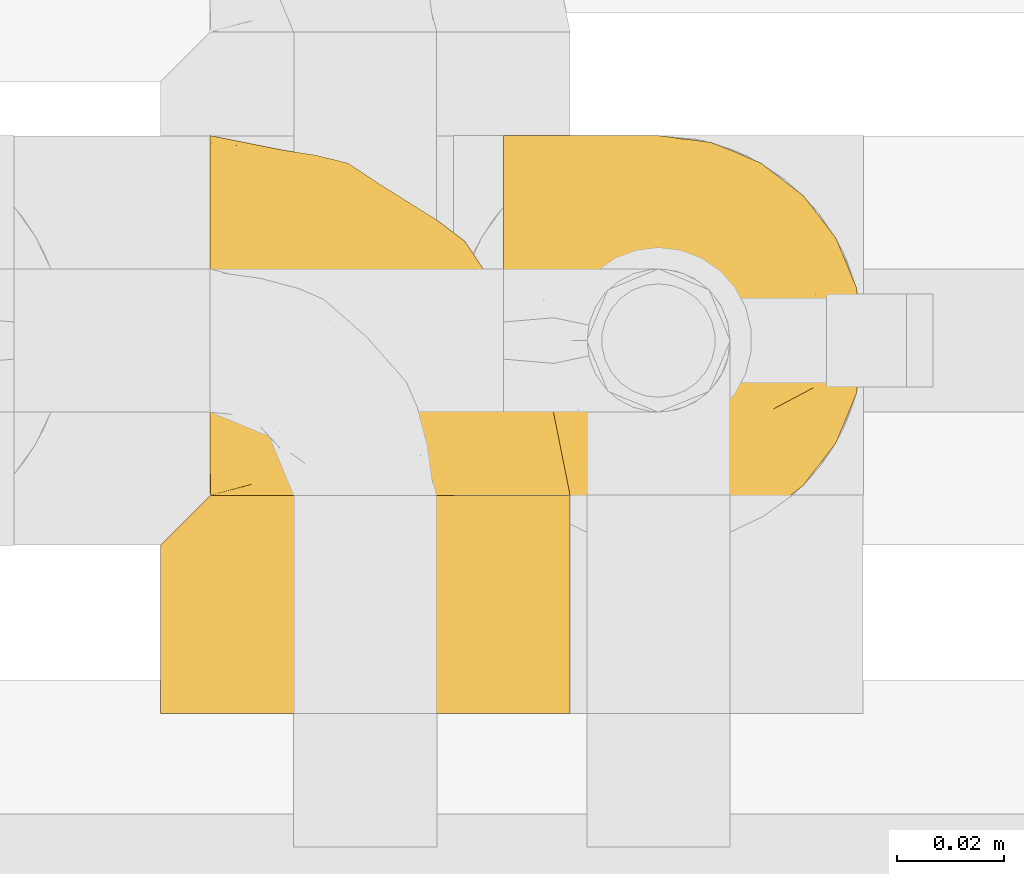
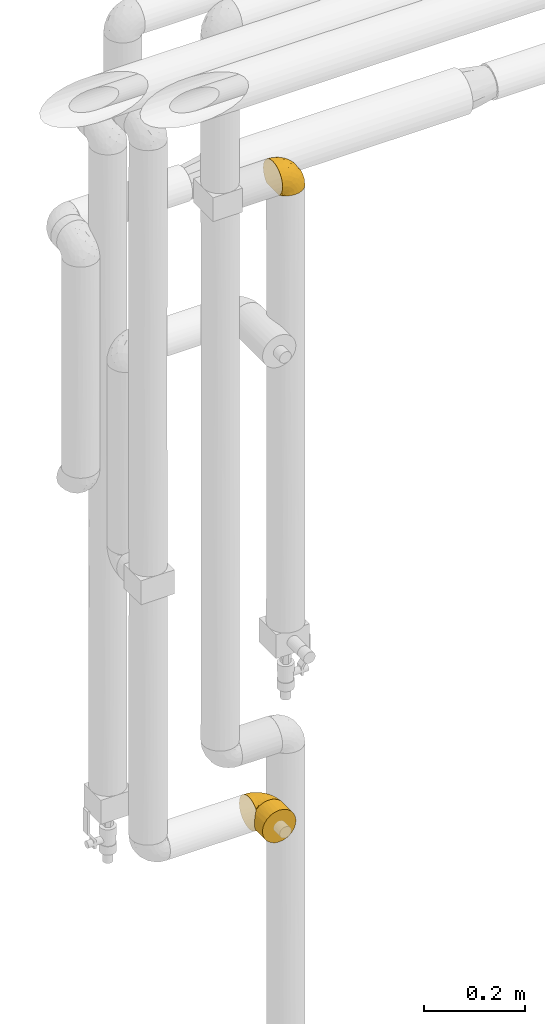
# One storey, part 331 of 827: 3 coverings.
"""IFC2X3 building model written with IfcOpenShell, lengths in millimetres."""

from ifc_helpers import new_model, entity, si_unit, converted_unit, derived_unit, direction, frame, origin, place, context, subcontext, project, spatial, faceted_brep, element, save


model = new_model("IFC2X3")

# Units and contexts
model_context = context("Model", 3, precision=0.01, world=origin(), true_north=direction((6.12303176911189e-17, 1.0)))
body_context = subcontext(model_context, "Body", "Model", "MODEL_VIEW")
ifc_project = project(units=[si_unit("LENGTHUNIT", "METRE", prefix="MILLI"), si_unit("AREAUNIT", "SQUARE_METRE"), si_unit("VOLUMEUNIT", "CUBIC_METRE"), converted_unit("PLANEANGLEUNIT", "DEGREE", entity("IfcRatioMeasure", 0.0174532925199433), si_unit("PLANEANGLEUNIT", "RADIAN"), dimensions=[0, 0, 0, 0, 0, 0, 0]), si_unit("MASSUNIT", "GRAM", prefix="KILO"), derived_unit("MASSDENSITYUNIT", [(si_unit("MASSUNIT", "GRAM", prefix="KILO"), 1), (si_unit("LENGTHUNIT", "METRE"), -3)]), derived_unit("MOMENTOFINERTIAUNIT", [(si_unit("LENGTHUNIT", "METRE"), 4)]), si_unit("TIMEUNIT", "SECOND"), si_unit("FREQUENCYUNIT", "HERTZ"), si_unit("THERMODYNAMICTEMPERATUREUNIT", "DEGREE_CELSIUS"), derived_unit("THERMALTRANSMITTANCEUNIT", [(si_unit("MASSUNIT", "GRAM", prefix="KILO"), 1), (si_unit("THERMODYNAMICTEMPERATUREUNIT", "KELVIN"), -1), (si_unit("TIMEUNIT", "SECOND"), -3)]), derived_unit("VOLUMETRICFLOWRATEUNIT", [(si_unit("LENGTHUNIT", "METRE"), 3), (si_unit("TIMEUNIT", "SECOND"), -1)]), derived_unit("MASSFLOWRATEUNIT", [(si_unit("MASSUNIT", "GRAM", prefix="KILO"), 1), (si_unit("TIMEUNIT", "SECOND"), -1)]), derived_unit("ROTATIONALFREQUENCYUNIT", [(si_unit("TIMEUNIT", "SECOND"), -1)]), si_unit("ELECTRICCURRENTUNIT", "AMPERE"), si_unit("ELECTRICVOLTAGEUNIT", "VOLT"), si_unit("POWERUNIT", "WATT"), si_unit("FORCEUNIT", "NEWTON", prefix="KILO"), si_unit("ILLUMINANCEUNIT", "LUX"), si_unit("LUMINOUSFLUXUNIT", "LUMEN"), si_unit("LUMINOUSINTENSITYUNIT", "CANDELA"), derived_unit("USERDEFINED", [(si_unit("MASSUNIT", "GRAM", prefix="KILO"), -1), (si_unit("LENGTHUNIT", "METRE"), -2), (si_unit("TIMEUNIT", "SECOND"), 3), (si_unit("LUMINOUSFLUXUNIT", "LUMEN"), 1)]), derived_unit("LINEARVELOCITYUNIT", [(si_unit("LENGTHUNIT", "METRE"), 1), (si_unit("TIMEUNIT", "SECOND"), -1)]), si_unit("PRESSUREUNIT", "PASCAL"), derived_unit("USERDEFINED", [(si_unit("LENGTHUNIT", "METRE"), -2), (si_unit("MASSUNIT", "GRAM", prefix="KILO"), 1), (si_unit("TIMEUNIT", "SECOND"), -2)]), derived_unit("LINEARFORCEUNIT", [(si_unit("MASSUNIT", "GRAM", prefix="KILO"), 1), (si_unit("LENGTHUNIT", "METRE"), 1), (si_unit("TIMEUNIT", "SECOND"), -2), (si_unit("LENGTHUNIT", "METRE"), -1)]), derived_unit("PLANARFORCEUNIT", [(si_unit("MASSUNIT", "GRAM", prefix="KILO"), 1), (si_unit("LENGTHUNIT", "METRE"), 1), (si_unit("TIMEUNIT", "SECOND"), -2), (si_unit("LENGTHUNIT", "METRE"), -2)])], contexts=[model_context])

# Site, building, storey
site_placement = place(None, origin())
site = spatial("IfcSite", under=ifc_project, at=site_placement, CompositionType="ELEMENT")
building_placement = place(site_placement, origin())
building = spatial("IfcBuilding", under=site, at=building_placement, CompositionType="ELEMENT")
storey_placement = place(building_placement, frame((0.0, 0.0, 28200.0)))
storey = spatial("IfcBuildingStorey", under=building, at=storey_placement, Name="08", CompositionType="ELEMENT", Elevation=28200.0)

# Coverings
covering_1_placement = place(storey_placement, frame((34809.73, 18294.87, 2549.3)))
element("IfcCovering", 1, at=covering_1_placement, inside=storey, Name=":ADSK_", ObjectType=":ADSK_", PredefinedType="INSULATION", context=body_context, shape_type="Brep", body=[
    faceted_brep([(1.6, 5.41, 47.38), (1.6, 9.99, 54.67), (1.6, 16.08, 60.76), (1.6, 23.37, 65.34), (1.6, 31.49, 68.18), (1.6, 40.05, 69.15), (1.6, 48.61, 68.18), (1.6, 56.73, 65.33), (1.6, 64.02, 60.75), (1.6, 70.11, 54.66), (1.6, 74.69, 47.37), (1.6, 77.53, 39.25), (1.6, 78.5, 30.7), (1.6, 77.63, 22.59), (1.6, 75.08, 14.86), (1.6, 70.97, 7.84), (1.6, 65.47, 1.85), (1.6, 63.27, 1.85), (1.6, 61.53, 1.85), (1.6, 59.57, 1.85), (1.6, 57.6, 1.85), (1.6, 55.63, 1.85), (1.6, 53.67, 1.85), (1.6, 51.7, 1.85), (1.6, 49.73, 1.85), (1.6, 47.54, 1.85), (1.6, 45.34, 1.85), (1.6, 43.15, 1.85), (1.6, 40.96, 1.85), (1.6, 38.76, 1.85), (1.6, 36.57, 1.85), (1.6, 34.37, 1.85), (1.6, 32.18, 1.85), (1.6, 29.98, 1.85), (1.6, 27.79, 1.85), (1.6, 25.6, 1.85), (1.6, 23.4, 1.85), (1.6, 21.21, 1.85), (1.6, 19.01, 1.85), (1.6, 16.82, 1.85), (1.6, 14.62, 1.85), (1.6, 9.12, 7.85), (1.6, 5.0, 14.88), (1.6, 2.46, 22.61), (1.6, 1.6, 30.7), (1.6, 2.56, 39.26), (1.85, 65.47, 1.6), (7.85, 70.97, 1.6), (14.87, 75.09, 1.6), (22.6, 77.63, 1.6), (30.7, 78.5, 1.6), (40.65, 77.19, 1.6), (49.92, 73.34, 1.6), (57.88, 67.23, 1.6), (63.99, 59.27, 1.6), (67.84, 50.0, 1.6), (69.15, 40.05, 1.6), (67.84, 30.09, 1.6), (63.99, 20.82, 1.6), (57.88, 12.86, 1.6), (49.92, 6.75, 1.6), (40.65, 2.91, 1.6), (30.7, 1.6, 1.6), (22.6, 2.46, 1.6), (14.87, 5.0, 1.6), (7.85, 9.12, 1.6), (1.85, 14.62, 1.6), (1.85, 16.82, 1.6), (1.85, 17.8, 1.6), (1.85, 19.39, 1.6), (1.85, 20.98, 1.6), (1.85, 22.57, 1.6), (1.85, 24.16, 1.6), (1.85, 25.75, 1.6), (1.85, 27.33, 1.6), (1.85, 28.92, 1.6), (1.85, 30.51, 1.6), (1.85, 32.1, 1.6), (1.85, 33.69, 1.6), (1.85, 35.28, 1.6), (1.85, 36.87, 1.6), (1.85, 38.46, 1.6), (1.85, 40.05, 1.6), (1.85, 41.63, 1.6), (1.85, 43.22, 1.6), (1.85, 44.81, 1.6), (1.85, 46.4, 1.6), (1.85, 47.99, 1.6), (1.85, 49.58, 1.6), (1.85, 51.17, 1.6), (1.85, 52.76, 1.6), (1.85, 54.72, 1.6), (1.85, 56.69, 1.6), (1.85, 58.88, 1.6), (1.85, 61.08, 1.6), (1.85, 63.27, 1.6), (1.77, 37.77, 1.78), (1.78, 36.07, 1.77), (1.77, 32.96, 1.78), (1.77, 31.36, 1.77), (1.76, 56.52, 1.79), (1.77, 54.96, 1.78), (1.79, 18.75, 1.76), (1.78, 58.07, 1.77), (1.78, 50.37, 1.77), (1.78, 23.36, 1.76), (1.78, 24.95, 1.77), (1.78, 42.43, 1.77), (1.74, 15.97, 1.8), (1.78, 51.96, 1.76), (1.78, 53.47, 1.77), (1.77, 48.63, 1.78), (1.78, 63.93, 1.77), (1.78, 40.93, 1.77), (1.78, 29.72, 1.76), (1.77, 62.4, 1.77), (1.77, 60.92, 1.78), (1.77, 17.31, 1.77), (1.78, 21.74, 1.77), (1.78, 34.56, 1.77), (1.77, 20.18, 1.78), (1.77, 14.62, 1.77), (1.72, 14.62, 1.8), (1.66, 14.62, 1.82), (1.77, 65.47, 1.77), (1.8, 65.47, 1.72), (1.82, 65.47, 1.66), (1.79, 59.5, 1.76), (1.78, 47.1, 1.77), (1.79, 45.61, 1.76), (1.78, 28.18, 1.77), (1.82, 14.62, 1.66), (1.8, 14.62, 1.72), (1.76, 26.61, 1.78), (1.66, 65.47, 1.82), (1.72, 65.47, 1.8), (1.78, 39.32, 1.77), (1.77, 44.12, 1.78), (9.41, 72.26, 3.72), (17.65, 76.57, 7.41), (7.41, 71.77, 6.13), (21.47, 78.5, 21.47), (15.21, 77.9, 19.34), (16.15, 78.5, 26.8), (28.75, 78.5, 8.87), (13.67, 75.52, 9.2), (12.79, 76.13, 12.79), (19.18, 77.81, 14.62), (29.16, 78.5, 7.34), (9.04, 72.4, 5.33), (7.41, 76.56, 17.64), (5.74, 71.77, 7.7), (3.72, 72.25, 9.41), (8.87, 78.5, 28.75), (26.8, 78.5, 16.15), (9.53, 75.75, 14.14), (7.34, 78.5, 29.16), (37.63, 50.46, 57.02), (17.92, 52.75, 64.92), (27.45, 40.05, 64.0), (37.01, 77.7, 11.92), (34.22, 77.66, 19.16), (45.87, 71.02, 28.65), (56.57, 63.45, 24.62), (52.31, 70.55, 15.19), (42.07, 75.57, 18.36), (44.74, 75.57, 9.2), (21.49, 72.61, 46.98), (11.02, 72.61, 50.24), (15.64, 67.24, 56.1), (26.02, 77.74, 28.97), (36.59, 57.43, 54.46), (65.49, 47.19, 21.34), (63.99, 54.76, 18.4), (15.2, 40.05, 66.44), (60.27, 63.45, 12.07), (45.25, 60.1, 45.49), (35.21, 63.72, 50.57), (22.52, 76.83, 36.04), (12.03, 76.34, 42.07), (13.32, 60.51, 62.12), (35.9, 72.59, 37.37), (33.87, 76.05, 29.39), (25.73, 66.15, 53.59), (26.34, 60.51, 58.06), (46.78, 51.88, 49.27), (59.54, 55.34, 29.63), (60.18, 48.67, 33.21), (53.93, 53.89, 40.1), (53.36, 46.73, 44.08), (49.36, 40.05, 49.36), (38.4, 40.05, 56.68), (66.44, 40.05, 15.2), (50.09, 63.95, 35.57), (41.08, 67.24, 41.7), (31.14, 69.62, 46.4), (28.19, 73.6, 41.41), (64.0, 40.05, 27.45), (56.68, 40.05, 38.4), (43.9, 4.52, 12.99), (65.46, 32.72, 21.33), (52.22, 27.18, 42.89), (37.61, 29.63, 57.04), (15.64, 12.86, 56.11), (13.31, 19.59, 62.13), (50.02, 9.54, 21.89), (59.28, 16.64, 16.62), (53.05, 17.48, 32.9), (21.48, 7.49, 46.99), (11.01, 7.49, 50.25), (12.03, 3.75, 42.08), (41.02, 20.75, 49.91), (35.39, 2.33, 15.6), (26.8, 1.6, 16.15), (28.75, 1.6, 8.87), (7.34, 1.6, 29.16), (65.81, 26.94, 13.16), (53.28, 9.54, 10.83), (59.8, 31.21, 33.8), (61.82, 25.33, 25.02), (17.91, 27.35, 64.92), (41.4, 8.17, 32.83), (40.48, 4.3, 20.56), (26.34, 19.59, 58.07), (31.68, 2.23, 21.46), (27.68, 2.45, 28.1), (16.15, 1.6, 26.8), (21.47, 1.6, 21.47), (28.05, 12.86, 51.29), (22.54, 3.27, 36.04), (8.87, 1.6, 28.75), (37.3, 2.29, 8.45), (41.07, 12.86, 41.73), (32.24, 6.89, 39.27), (47.4, 12.43, 33.56), (35.77, 4.1, 27.29), (17.65, 3.53, 7.41), (11.06, 6.88, 3.51), (8.55, 8.16, 4.68), (6.63, 9.02, 5.52), (12.77, 5.0, 8.75), (12.79, 3.96, 12.79), (7.41, 3.52, 17.65), (18.97, 2.4, 13.9), (3.72, 7.83, 9.42), (5.76, 8.32, 7.68), (15.21, 2.19, 19.33), (9.52, 4.34, 14.13)], [[[0, 1, 2, 3, 4, 5, 6, 7, 8, 9, 10, 11, 12, 13, 14, 15, 16, 17, 18, 19, 20, 21, 22, 23, 24, 25, 26, 27, 28, 29, 30, 31, 32, 33, 34, 35, 36, 37, 38, 39, 40, 41, 42, 43, 44, 45]], [[46, 47, 48, 49, 50, 51, 52, 53, 54, 55, 56, 57, 58, 59, 60, 61, 62, 63, 64, 65, 66, 67, 68, 69, 70, 71, 72, 73, 74, 75, 76, 77, 78, 79, 80, 81, 82, 83, 84, 85, 86, 87, 88, 89, 90, 91, 92, 93, 94, 95]], [[96, 97, 30]], [[98, 77, 99]], [[100, 101, 21]], [[69, 68, 102]], [[20, 19, 103]], [[24, 23, 104]], [[20, 103, 100]], [[72, 105, 106]], [[84, 83, 107]], [[89, 88, 104]], [[108, 67, 66]], [[109, 110, 90]], [[111, 25, 24]], [[112, 17, 16]], [[82, 113, 83]], [[109, 23, 22]], [[114, 76, 75]], [[105, 36, 106]], [[104, 111, 24]], [[18, 115, 116]], [[97, 96, 80]], [[67, 108, 117]], [[105, 71, 118]], [[31, 97, 119]], [[102, 120, 69]], [[108, 121, 122, 123, 40]], [[112, 95, 115]], [[17, 115, 18]], [[94, 116, 115]], [[117, 68, 67]], [[38, 117, 39]], [[112, 124, 125, 126, 46]], [[17, 112, 115]], [[70, 120, 118]], [[39, 117, 108]], [[120, 38, 37]], [[120, 37, 118]], [[120, 70, 69]], [[116, 94, 127]], [[128, 86, 129]], [[117, 38, 102]], [[74, 130, 75]], [[99, 33, 32]], [[115, 95, 94]], [[39, 108, 40]], [[108, 66, 131, 132, 121]], [[105, 72, 71]], [[118, 37, 36]], [[71, 70, 118]], [[35, 106, 36]], [[36, 105, 118]], [[35, 133, 106]], [[74, 73, 133]], [[106, 133, 73]], [[99, 114, 33]], [[133, 35, 34]], [[73, 72, 106]], [[95, 112, 46]], [[112, 16, 134, 135, 124]], [[130, 114, 75]], [[99, 76, 114]], [[114, 130, 33]], [[34, 33, 130]], [[78, 77, 98]], [[98, 119, 78]], [[130, 133, 34]], [[133, 130, 74]], [[79, 97, 80]], [[98, 99, 32]], [[98, 32, 31]], [[77, 76, 99]], [[97, 79, 119]], [[136, 96, 29]], [[30, 97, 31]], [[136, 29, 28]], [[81, 80, 96]], [[29, 96, 30]], [[31, 119, 98]], [[119, 79, 78]], [[96, 136, 81]], [[82, 81, 136]], [[113, 107, 83]], [[84, 107, 137]], [[107, 27, 137]], [[113, 28, 107]], [[27, 107, 28]], [[85, 84, 137]], [[137, 27, 26]], [[113, 136, 28]], [[136, 113, 82]], [[109, 89, 104]], [[86, 85, 129]], [[89, 109, 90]], [[111, 87, 128]], [[26, 129, 137]], [[88, 111, 104]], [[25, 111, 128]], [[22, 110, 109]], [[23, 109, 104]], [[110, 91, 90]], [[100, 92, 101]], [[110, 22, 101]], [[91, 110, 101]], [[116, 19, 18]], [[111, 88, 87]], [[127, 103, 19]], [[25, 128, 26]], [[86, 128, 87]], [[128, 129, 26]], [[137, 129, 85]], [[120, 102, 38]], [[117, 102, 68]], [[91, 101, 92]], [[21, 101, 22]], [[93, 92, 103]], [[100, 21, 20]], [[100, 103, 92]], [[127, 93, 103]], [[93, 127, 94]], [[116, 127, 19]], [[126, 138, 47]], [[48, 138, 139]], [[140, 125, 124]], [[141, 142, 143]], [[144, 49, 139]], [[145, 140, 146]], [[48, 139, 49]], [[139, 145, 147]], [[49, 144, 148, 50]], [[126, 125, 149]], [[14, 13, 150]], [[151, 146, 140]], [[149, 140, 145]], [[152, 151, 135]], [[152, 14, 150]], [[16, 15, 134]], [[13, 153, 150]], [[124, 151, 140]], [[141, 147, 142]], [[14, 152, 15]], [[15, 152, 134]], [[47, 46, 126]], [[139, 154, 144]], [[138, 48, 47]], [[125, 140, 149]], [[135, 134, 152]], [[146, 155, 142]], [[145, 146, 147]], [[149, 139, 138]], [[147, 141, 154]], [[147, 146, 142]], [[139, 147, 154]], [[139, 149, 145]], [[149, 138, 126]], [[155, 146, 151]], [[150, 143, 142]], [[152, 155, 151]], [[150, 142, 155]], [[13, 12, 156, 153]], [[153, 143, 150]], [[152, 150, 155]], [[151, 124, 135]], [[157, 158, 159]], [[160, 154, 161]], [[162, 163, 164]], [[165, 166, 160]], [[167, 168, 169]], [[141, 170, 161]], [[156, 12, 11]], [[158, 157, 171]], [[172, 55, 173]], [[158, 6, 174]], [[175, 54, 53]], [[52, 166, 164]], [[52, 164, 53]], [[54, 175, 173]], [[166, 52, 51]], [[176, 177, 171]], [[178, 143, 179]], [[156, 11, 179]], [[8, 7, 180]], [[169, 9, 8]], [[179, 143, 153, 156]], [[179, 11, 10]], [[168, 179, 10]], [[181, 162, 182]], [[179, 167, 178]], [[183, 184, 177]], [[183, 169, 184]], [[176, 171, 185]], [[172, 186, 187]], [[158, 7, 6]], [[159, 158, 174]], [[184, 180, 158]], [[54, 173, 55]], [[180, 169, 8]], [[188, 189, 187]], [[9, 168, 10]], [[186, 188, 187]], [[190, 157, 159, 191]], [[55, 172, 192]], [[176, 193, 194]], [[161, 170, 182]], [[162, 164, 165]], [[175, 164, 163]], [[51, 50, 148]], [[167, 195, 196]], [[178, 182, 170]], [[6, 5, 174]], [[158, 180, 7]], [[169, 180, 184]], [[169, 168, 9]], [[179, 168, 167]], [[182, 162, 165]], [[162, 194, 193]], [[161, 165, 160]], [[195, 181, 196]], [[192, 172, 197]], [[192, 56, 55]], [[189, 190, 198]], [[198, 197, 187]], [[172, 187, 197]], [[185, 189, 188]], [[198, 187, 189]], [[186, 172, 173]], [[173, 163, 186]], [[193, 186, 163]], [[176, 185, 188]], [[185, 157, 190]], [[188, 186, 193]], [[177, 176, 194]], [[188, 193, 176]], [[162, 193, 163]], [[195, 177, 194]], [[171, 177, 184]], [[181, 195, 194]], [[183, 167, 169]], [[162, 181, 194]], [[196, 182, 178]], [[158, 171, 184]], [[171, 157, 185]], [[177, 195, 183]], [[167, 183, 195]], [[182, 196, 181]], [[178, 170, 143]], [[178, 167, 196]], [[164, 175, 53]], [[173, 175, 163]], [[160, 51, 148]], [[164, 166, 165]], [[51, 160, 166]], [[160, 148, 144, 154]], [[141, 161, 154]], [[182, 165, 161]], [[190, 189, 185]], [[143, 170, 141]], [[60, 199, 61]], [[197, 200, 192]], [[201, 190, 202]], [[200, 57, 192]], [[203, 204, 2]], [[205, 206, 207]], [[208, 209, 210]], [[211, 207, 201]], [[212, 213, 214]], [[45, 215, 210]], [[216, 206, 58]], [[45, 44, 215]], [[59, 217, 60]], [[60, 217, 199]], [[0, 45, 210]], [[218, 201, 219]], [[202, 159, 220]], [[205, 221, 222]], [[223, 204, 203]], [[1, 203, 2]], [[57, 200, 216]], [[220, 3, 204]], [[220, 174, 4]], [[1, 0, 209]], [[212, 224, 213]], [[225, 226, 227]], [[228, 223, 203]], [[208, 210, 229]], [[210, 226, 229]], [[3, 220, 4]], [[58, 206, 59]], [[209, 203, 1]], [[202, 220, 223]], [[228, 203, 208]], [[202, 211, 201]], [[3, 2, 204]], [[202, 190, 191, 159]], [[210, 215, 230, 226]], [[199, 212, 231]], [[232, 233, 221]], [[233, 208, 229]], [[207, 206, 219]], [[217, 206, 205]], [[227, 224, 225]], [[233, 232, 228]], [[201, 207, 219]], [[234, 232, 221]], [[218, 219, 200]], [[202, 223, 211]], [[174, 220, 159]], [[174, 5, 4]], [[61, 231, 62]], [[220, 204, 223]], [[210, 209, 0]], [[203, 209, 208]], [[225, 233, 229]], [[224, 227, 213]], [[221, 233, 235]], [[57, 56, 192]], [[198, 218, 197]], [[200, 219, 216]], [[201, 198, 190]], [[197, 218, 200]], [[198, 201, 218]], [[206, 216, 219]], [[58, 57, 216]], [[231, 212, 214]], [[222, 212, 199]], [[228, 211, 223]], [[207, 211, 232]], [[62, 231, 214]], [[199, 231, 61]], [[233, 228, 208]], [[211, 228, 232]], [[222, 221, 235]], [[234, 205, 207]], [[206, 217, 59]], [[199, 217, 205]], [[205, 222, 199]], [[224, 222, 235]], [[222, 224, 212]], [[224, 235, 225]], [[233, 225, 235]], [[226, 225, 229]], [[205, 234, 221]], [[207, 232, 234]], [[63, 214, 236]], [[214, 213, 236]], [[214, 63, 62]], [[237, 236, 238]], [[238, 132, 131]], [[236, 237, 64]], [[239, 240, 241]], [[63, 236, 64]], [[131, 66, 65]], [[237, 131, 65]], [[242, 230, 43]], [[237, 65, 64]], [[239, 121, 132]], [[42, 242, 43]], [[241, 240, 243]], [[41, 123, 244]], [[43, 230, 215, 44]], [[244, 122, 245]], [[227, 246, 243]], [[241, 243, 246]], [[121, 239, 245]], [[41, 40, 123]], [[132, 238, 239]], [[244, 42, 41]], [[131, 237, 238]], [[240, 239, 238]], [[245, 239, 241]], [[247, 241, 246]], [[247, 244, 245]], [[238, 236, 240]], [[243, 236, 213]], [[236, 243, 240]], [[226, 246, 227]], [[243, 213, 227]], [[226, 242, 246]], [[241, 247, 245]], [[246, 242, 247]], [[244, 247, 242]], [[242, 226, 230]], [[42, 244, 242]], [[122, 244, 123]], [[122, 121, 245]]]),
])
covering_2_placement = place(storey_placement, frame((34745.39, 18264.91, 1020.0)))
element("IfcCovering", 2, at=covering_2_placement, inside=storey, Name=":ADSK_", ObjectType=":ADSK_", PredefinedType="INSULATION", context=body_context, shape_type="Brep", body=[
    faceted_brep([(16.91, 40.9, 70.68), (23.98, 40.9, 74.9), (31.79, 40.9, 77.51), (40.0, 40.9, 78.4), (49.93, 40.9, 77.09), (59.2, 40.9, 73.25), (67.15, 40.9, 67.15), (73.25, 40.9, 59.2), (77.09, 40.9, 49.93), (78.4, 40.9, 40.0), (77.09, 40.9, 30.06), (73.25, 40.9, 20.8), (67.15, 40.9, 12.84), (59.2, 40.9, 6.74), (49.93, 40.9, 2.9), (40.0, 40.9, 1.6), (31.79, 40.9, 2.48), (23.98, 40.9, 5.09), (16.91, 40.9, 9.31), (10.9, 40.9, 14.94), (10.9, 40.9, 65.05), (20.8, 0.0, 73.25), (12.84, 0.0, 67.15), (6.74, 0.0, 59.2), (2.9, 0.0, 49.93), (1.6, 0.0, 40.0), (2.9, 0.0, 30.06), (6.74, 0.0, 20.8), (12.84, 0.0, 12.84), (20.8, 0.0, 6.74), (30.06, 0.0, 2.9), (40.0, 0.0, 1.6), (49.93, 0.0, 2.9), (59.2, 0.0, 6.74), (67.15, 0.0, 12.84), (73.25, 0.0, 20.8), (77.09, 0.0, 30.06), (78.4, 0.0, 40.0), (77.09, 0.0, 49.93), (73.25, 0.0, 59.2), (67.15, 0.0, 67.15), (59.2, 0.0, 73.25), (49.93, 0.0, 77.09), (40.0, 0.0, 78.4), (30.06, 0.0, 77.09), (4.0, 34.0, 26.63), (2.2, 32.2, 33.21), (1.6, 31.6, 40.0), (6.92, 36.93, 20.48), (2.2, 32.2, 46.78), (4.0, 34.0, 53.36), (6.92, 36.93, 59.51)], [[[0, 1, 2, 3, 4, 5, 6, 7, 8, 9, 10, 11, 12, 13, 14, 15, 16, 17, 18, 19, 20]], [[21, 22, 23, 24, 25, 26, 27, 28, 29, 30, 31, 32, 33, 34, 35, 36, 37, 38, 39, 40, 41, 42, 43, 44]], [[9, 37, 36, 10]], [[10, 36, 35, 11]], [[12, 11, 35, 34]], [[14, 13, 33, 32]], [[15, 14, 32, 31]], [[34, 33, 13, 12]], [[16, 31, 30]], [[29, 28, 18]], [[17, 30, 29]], [[15, 31, 16]], [[17, 16, 30]], [[18, 17, 29]], [[28, 19, 18]], [[45, 27, 26]], [[26, 25, 46]], [[47, 46, 25]], [[19, 28, 48]], [[46, 45, 26]], [[48, 27, 45]], [[48, 28, 27]], [[49, 47, 25]], [[49, 25, 24]], [[50, 24, 23]], [[50, 49, 24]], [[22, 20, 51]], [[50, 23, 51]], [[51, 23, 22]], [[0, 22, 21]], [[1, 21, 44]], [[2, 44, 43]], [[0, 21, 1]], [[1, 44, 2]], [[43, 3, 2]], [[22, 0, 20]], [[42, 41, 5, 4]], [[43, 42, 4, 3]], [[6, 5, 41, 40]], [[8, 7, 39, 38]], [[9, 8, 38, 37]], [[40, 39, 7, 6]], [[46, 47, 49, 50, 51, 20, 19, 48, 45]]]),
])
covering_3_placement = place(storey_placement, frame((34754.69, 18304.22, 1019.95)))
element("IfcCovering", 3, at=covering_3_placement, inside=storey, Name=":ADSK_", ObjectType=":ADSK_", PredefinedType="INSULATION", context=body_context, shape_type="Brep", body=[
    faceted_brep([(47.38, 1.6, 5.41), (54.67, 1.6, 9.99), (60.76, 1.6, 16.08), (65.34, 1.6, 23.37), (68.18, 1.6, 31.49), (69.15, 1.6, 40.05), (68.18, 1.6, 48.61), (65.33, 1.6, 56.73), (60.75, 1.6, 64.02), (54.66, 1.6, 70.11), (47.37, 1.6, 74.69), (39.25, 1.6, 77.53), (30.7, 1.6, 78.5), (22.59, 1.6, 77.63), (14.86, 1.6, 75.08), (7.84, 1.6, 70.97), (1.85, 1.6, 65.47), (1.85, 1.6, 63.27), (1.85, 1.6, 61.53), (1.85, 1.6, 59.57), (1.85, 1.6, 57.6), (1.85, 1.6, 55.63), (1.85, 1.6, 53.67), (1.85, 1.6, 51.7), (1.85, 1.6, 49.73), (1.85, 1.6, 47.54), (1.85, 1.6, 45.34), (1.85, 1.6, 43.15), (1.85, 1.6, 40.96), (1.85, 1.6, 38.76), (1.85, 1.6, 36.57), (1.85, 1.6, 34.37), (1.85, 1.6, 32.18), (1.85, 1.6, 29.98), (1.85, 1.6, 27.79), (1.85, 1.6, 25.6), (1.85, 1.6, 23.4), (1.85, 1.6, 21.21), (1.85, 1.6, 19.01), (1.85, 1.6, 16.82), (1.85, 1.6, 14.62), (7.85, 1.6, 9.12), (14.88, 1.6, 5.0), (22.61, 1.6, 2.46), (30.7, 1.6, 1.6), (39.26, 1.6, 2.56), (1.6, 1.85, 65.47), (1.6, 7.85, 70.97), (1.6, 14.87, 75.09), (1.6, 22.6, 77.63), (1.6, 30.7, 78.5), (1.6, 40.65, 77.19), (1.6, 49.92, 73.34), (1.6, 57.88, 67.23), (1.6, 63.99, 59.27), (1.6, 67.84, 50.0), (1.6, 69.15, 40.05), (1.6, 67.84, 30.09), (1.6, 63.99, 20.82), (1.6, 57.88, 12.86), (1.6, 49.92, 6.75), (1.6, 40.65, 2.91), (1.6, 30.7, 1.6), (1.6, 22.6, 2.46), (1.6, 14.87, 5.0), (1.6, 7.85, 9.12), (1.6, 1.85, 14.62), (1.6, 1.85, 16.82), (1.6, 1.85, 17.8), (1.6, 1.85, 19.39), (1.6, 1.85, 20.98), (1.6, 1.85, 22.57), (1.6, 1.85, 24.16), (1.6, 1.85, 25.75), (1.6, 1.85, 27.33), (1.6, 1.85, 28.92), (1.6, 1.85, 30.51), (1.6, 1.85, 32.1), (1.6, 1.85, 33.69), (1.6, 1.85, 35.28), (1.6, 1.85, 36.87), (1.6, 1.85, 38.46), (1.6, 1.85, 40.05), (1.6, 1.85, 41.63), (1.6, 1.85, 43.22), (1.6, 1.85, 44.81), (1.6, 1.85, 46.4), (1.6, 1.85, 47.99), (1.6, 1.85, 49.58), (1.6, 1.85, 51.17), (1.6, 1.85, 52.76), (1.6, 1.85, 54.72), (1.6, 1.85, 56.69), (1.6, 1.85, 58.88), (1.6, 1.85, 61.08), (1.6, 1.85, 63.27), (1.78, 1.77, 37.77), (1.77, 1.78, 36.07), (1.78, 1.77, 32.96), (1.77, 1.77, 31.36), (1.79, 1.76, 56.52), (1.78, 1.77, 54.96), (1.76, 1.79, 18.75), (1.77, 1.78, 58.07), (1.77, 1.78, 50.37), (1.76, 1.78, 23.36), (1.77, 1.78, 24.95), (1.77, 1.78, 42.43), (1.8, 1.74, 15.97), (1.76, 1.78, 51.96), (1.77, 1.78, 53.47), (1.78, 1.77, 48.63), (1.77, 1.78, 63.93), (1.77, 1.78, 40.93), (1.76, 1.78, 29.72), (1.77, 1.77, 62.4), (1.78, 1.77, 60.92), (1.77, 1.77, 17.31), (1.77, 1.78, 21.74), (1.77, 1.78, 34.56), (1.78, 1.77, 20.18), (1.77, 1.77, 14.62), (1.8, 1.72, 14.62), (1.82, 1.66, 14.62), (1.77, 1.77, 65.47), (1.72, 1.8, 65.47), (1.66, 1.82, 65.47), (1.76, 1.79, 59.5), (1.77, 1.78, 47.1), (1.76, 1.79, 45.61), (1.77, 1.78, 28.18), (1.66, 1.82, 14.62), (1.72, 1.8, 14.62), (1.78, 1.76, 26.61), (1.82, 1.66, 65.47), (1.8, 1.72, 65.47), (1.77, 1.78, 39.32), (1.78, 1.77, 44.12), (3.72, 9.41, 72.26), (7.41, 17.65, 76.57), (6.13, 7.41, 71.77), (21.47, 21.47, 78.5), (19.34, 15.21, 77.9), (26.8, 16.15, 78.5), (8.87, 28.75, 78.5), (9.2, 13.67, 75.52), (12.79, 12.79, 76.13), (14.62, 19.18, 77.81), (5.33, 9.04, 72.4), (17.64, 7.41, 76.56), (7.7, 5.74, 71.77), (9.41, 3.72, 72.25), (28.75, 8.87, 78.5), (16.15, 26.8, 78.5), (14.14, 9.53, 75.75), (29.16, 7.34, 78.5), (9.2, 44.74, 75.57), (42.07, 12.03, 76.34), (11.99, 37.26, 77.64), (24.62, 56.57, 63.45), (15.19, 52.31, 70.55), (28.65, 45.87, 71.02), (53.59, 25.73, 66.15), (58.06, 26.34, 60.51), (50.57, 35.21, 63.72), (18.36, 42.07, 75.57), (46.98, 21.49, 72.61), (36.04, 22.52, 76.83), (50.24, 11.02, 72.61), (56.1, 15.64, 67.24), (21.34, 65.49, 47.19), (18.4, 63.99, 54.76), (12.07, 60.27, 63.45), (64.92, 17.92, 52.75), (40.1, 53.93, 53.89), (44.08, 53.36, 46.73), (33.21, 60.18, 48.67), (29.63, 59.54, 55.34), (49.36, 49.36, 40.05), (57.02, 37.63, 50.46), (64.0, 27.45, 40.05), (56.68, 38.4, 40.05), (28.97, 26.02, 77.74), (19.16, 34.22, 77.66), (54.46, 36.59, 57.43), (66.44, 15.2, 40.05), (62.12, 13.32, 60.51), (45.49, 45.25, 60.1), (49.27, 46.78, 51.88), (37.37, 35.9, 72.59), (29.39, 33.87, 76.05), (15.2, 66.44, 40.05), (35.57, 50.09, 63.95), (41.7, 41.08, 67.24), (46.4, 31.14, 69.62), (41.41, 28.19, 73.6), (27.45, 64.0, 40.05), (38.4, 56.68, 40.05), (21.33, 65.46, 32.72), (29.16, 7.34, 1.6), (42.08, 12.03, 3.75), (57.04, 37.61, 29.63), (42.89, 52.22, 27.18), (64.92, 17.91, 27.35), (58.07, 26.34, 19.59), (51.29, 28.05, 12.86), (56.11, 15.64, 12.86), (46.99, 21.48, 7.49), (21.89, 50.02, 9.54), (16.62, 59.28, 16.64), (32.9, 53.05, 17.48), (15.6, 35.39, 2.33), (16.15, 26.8, 1.6), (8.87, 28.75, 1.6), (32.83, 41.4, 8.17), (20.56, 40.48, 4.3), (13.16, 65.81, 26.94), (49.91, 41.02, 20.75), (10.83, 53.28, 9.54), (12.99, 43.9, 4.52), (50.25, 11.01, 7.49), (28.75, 8.87, 1.6), (26.8, 16.15, 1.6), (62.13, 13.31, 19.59), (36.04, 22.54, 3.27), (28.1, 27.68, 2.45), (21.47, 21.47, 1.6), (33.8, 59.8, 31.21), (25.02, 61.82, 25.33), (8.45, 37.3, 2.29), (41.73, 41.07, 12.86), (39.27, 32.24, 6.89), (21.46, 31.68, 2.23), (33.56, 47.4, 12.43), (27.29, 35.77, 4.1), (7.41, 17.65, 3.53), (3.51, 11.06, 6.88), (4.68, 8.55, 8.16), (5.52, 6.63, 9.02), (8.75, 12.77, 5.0), (12.79, 12.79, 3.96), (17.65, 7.41, 3.52), (13.9, 18.97, 2.4), (9.42, 3.72, 7.83), (7.68, 5.76, 8.32), (19.33, 15.21, 2.19), (14.13, 9.52, 4.34)], [[[0, 1, 2, 3, 4, 5, 6, 7, 8, 9, 10, 11, 12, 13, 14, 15, 16, 17, 18, 19, 20, 21, 22, 23, 24, 25, 26, 27, 28, 29, 30, 31, 32, 33, 34, 35, 36, 37, 38, 39, 40, 41, 42, 43, 44, 45]], [[46, 47, 48, 49, 50, 51, 52, 53, 54, 55, 56, 57, 58, 59, 60, 61, 62, 63, 64, 65, 66, 67, 68, 69, 70, 71, 72, 73, 74, 75, 76, 77, 78, 79, 80, 81, 82, 83, 84, 85, 86, 87, 88, 89, 90, 91, 92, 93, 94, 95]], [[96, 97, 30]], [[98, 77, 99]], [[100, 101, 21]], [[69, 68, 102]], [[20, 19, 103]], [[24, 23, 104]], [[20, 103, 100]], [[72, 105, 106]], [[84, 83, 107]], [[89, 88, 104]], [[108, 67, 66]], [[109, 110, 90]], [[111, 25, 24]], [[112, 17, 16]], [[82, 113, 83]], [[109, 23, 22]], [[114, 76, 75]], [[105, 36, 106]], [[104, 111, 24]], [[18, 115, 116]], [[97, 96, 80]], [[67, 108, 117]], [[105, 71, 118]], [[31, 97, 119]], [[102, 120, 69]], [[108, 121, 122, 123, 40]], [[112, 95, 115]], [[17, 115, 18]], [[94, 116, 115]], [[117, 68, 67]], [[38, 117, 39]], [[112, 124, 125, 126, 46]], [[17, 112, 115]], [[70, 120, 118]], [[39, 117, 108]], [[120, 38, 37]], [[120, 37, 118]], [[120, 70, 69]], [[116, 94, 127]], [[128, 86, 129]], [[117, 38, 102]], [[74, 130, 75]], [[99, 33, 32]], [[115, 95, 94]], [[39, 108, 40]], [[108, 66, 131, 132, 121]], [[105, 72, 71]], [[118, 37, 36]], [[71, 70, 118]], [[35, 106, 36]], [[36, 105, 118]], [[35, 133, 106]], [[74, 73, 133]], [[106, 133, 73]], [[99, 114, 33]], [[133, 35, 34]], [[73, 72, 106]], [[95, 112, 46]], [[112, 16, 134, 135, 124]], [[130, 114, 75]], [[99, 76, 114]], [[114, 130, 33]], [[34, 33, 130]], [[78, 77, 98]], [[98, 119, 78]], [[130, 133, 34]], [[133, 130, 74]], [[79, 97, 80]], [[98, 99, 32]], [[98, 32, 31]], [[77, 76, 99]], [[97, 79, 119]], [[136, 96, 29]], [[30, 97, 31]], [[136, 29, 28]], [[81, 80, 96]], [[29, 96, 30]], [[31, 119, 98]], [[119, 79, 78]], [[96, 136, 81]], [[82, 81, 136]], [[113, 107, 83]], [[84, 107, 137]], [[107, 27, 137]], [[113, 28, 107]], [[27, 107, 28]], [[85, 84, 137]], [[137, 27, 26]], [[113, 136, 28]], [[136, 113, 82]], [[109, 89, 104]], [[86, 85, 129]], [[89, 109, 90]], [[111, 87, 128]], [[26, 129, 137]], [[88, 111, 104]], [[25, 111, 128]], [[22, 110, 109]], [[23, 109, 104]], [[110, 91, 90]], [[100, 92, 101]], [[110, 22, 101]], [[91, 110, 101]], [[116, 19, 18]], [[111, 88, 87]], [[127, 103, 19]], [[25, 128, 26]], [[86, 128, 87]], [[128, 129, 26]], [[137, 129, 85]], [[120, 102, 38]], [[117, 102, 68]], [[91, 101, 92]], [[21, 101, 22]], [[93, 92, 103]], [[100, 21, 20]], [[100, 103, 92]], [[127, 93, 103]], [[93, 127, 94]], [[116, 127, 19]], [[126, 138, 47]], [[48, 138, 139]], [[140, 125, 124]], [[141, 142, 143]], [[144, 49, 139]], [[145, 140, 146]], [[48, 139, 49]], [[139, 145, 147]], [[144, 50, 49]], [[126, 125, 148]], [[14, 13, 149]], [[150, 146, 140]], [[148, 140, 145]], [[151, 150, 135]], [[151, 14, 149]], [[16, 15, 134]], [[13, 152, 149]], [[124, 150, 140]], [[141, 147, 142]], [[14, 151, 15]], [[15, 151, 134]], [[47, 46, 126]], [[139, 153, 144]], [[138, 48, 47]], [[125, 140, 148]], [[135, 134, 151]], [[146, 154, 142]], [[145, 146, 147]], [[148, 139, 138]], [[147, 141, 153]], [[147, 146, 142]], [[139, 147, 153]], [[139, 148, 145]], [[148, 138, 126]], [[154, 146, 150]], [[149, 143, 142]], [[151, 154, 150]], [[149, 142, 154]], [[13, 12, 155, 152]], [[152, 143, 149]], [[151, 149, 154]], [[150, 124, 135]], [[51, 156, 52]], [[155, 11, 157]], [[50, 144, 158]], [[159, 160, 161]], [[162, 163, 164]], [[158, 165, 156]], [[157, 166, 167]], [[166, 168, 169]], [[170, 55, 171]], [[161, 160, 165]], [[172, 54, 53]], [[160, 53, 52]], [[173, 7, 6]], [[54, 172, 171]], [[174, 175, 176]], [[170, 177, 176]], [[167, 143, 157]], [[178, 179, 180, 181]], [[157, 11, 10]], [[141, 182, 183]], [[160, 52, 156]], [[173, 179, 184]], [[8, 169, 9]], [[173, 6, 185]], [[155, 12, 11]], [[8, 7, 186]], [[162, 169, 163]], [[187, 184, 188]], [[180, 173, 185]], [[10, 168, 157]], [[54, 171, 55]], [[186, 173, 163]], [[157, 143, 152, 155]], [[189, 161, 190]], [[179, 173, 180]], [[9, 168, 10]], [[186, 169, 8]], [[187, 164, 184]], [[144, 183, 158]], [[172, 160, 159]], [[177, 174, 176]], [[55, 170, 191]], [[187, 192, 193]], [[183, 182, 190]], [[166, 194, 195]], [[167, 190, 182]], [[6, 5, 185]], [[173, 186, 7]], [[169, 186, 163]], [[169, 168, 9]], [[157, 168, 166]], [[190, 161, 165]], [[161, 193, 192]], [[183, 165, 158]], [[194, 189, 195]], [[191, 170, 196]], [[191, 56, 55]], [[175, 178, 197]], [[197, 196, 176]], [[170, 176, 196]], [[188, 175, 174]], [[197, 176, 175]], [[177, 170, 171]], [[171, 159, 177]], [[192, 177, 159]], [[187, 188, 174]], [[188, 179, 178]], [[174, 177, 192]], [[164, 187, 193]], [[174, 192, 187]], [[161, 192, 159]], [[194, 164, 193]], [[184, 164, 163]], [[189, 194, 193]], [[162, 166, 169]], [[161, 189, 193]], [[195, 190, 167]], [[173, 184, 163]], [[184, 179, 188]], [[164, 194, 162]], [[166, 162, 194]], [[190, 195, 189]], [[167, 182, 143]], [[167, 166, 195]], [[160, 172, 53]], [[171, 172, 159]], [[51, 50, 158]], [[160, 156, 165]], [[51, 158, 156]], [[183, 144, 153]], [[141, 183, 153]], [[190, 165, 183]], [[178, 175, 188]], [[143, 182, 141]], [[198, 191, 196]], [[45, 199, 200]], [[178, 201, 202]], [[201, 203, 204]], [[205, 206, 207]], [[57, 56, 191]], [[4, 185, 5]], [[208, 209, 210]], [[211, 212, 213]], [[208, 214, 215]], [[216, 209, 58]], [[201, 217, 202]], [[59, 218, 60]], [[60, 218, 219]], [[201, 178, 181, 180]], [[1, 0, 220]], [[201, 180, 203]], [[200, 199, 221, 222]], [[203, 185, 4]], [[3, 203, 4]], [[2, 1, 206]], [[217, 210, 202]], [[58, 209, 59]], [[3, 223, 203]], [[207, 220, 200]], [[204, 223, 206]], [[205, 204, 206]], [[207, 200, 224]], [[200, 222, 224]], [[206, 223, 2]], [[225, 222, 226]], [[220, 206, 1]], [[60, 219, 61]], [[57, 198, 216]], [[227, 202, 228]], [[3, 2, 223]], [[45, 44, 199]], [[0, 45, 200]], [[219, 211, 229]], [[230, 231, 214]], [[231, 207, 224]], [[210, 209, 228]], [[218, 209, 208]], [[226, 232, 225]], [[231, 230, 205]], [[202, 210, 228]], [[233, 230, 214]], [[227, 228, 198]], [[201, 204, 217]], [[211, 232, 212]], [[180, 185, 203]], [[61, 229, 62]], [[203, 223, 204]], [[200, 220, 0]], [[206, 220, 207]], [[225, 231, 224]], [[232, 226, 212]], [[214, 231, 234]], [[197, 227, 196]], [[191, 198, 57]], [[198, 228, 216]], [[202, 197, 178]], [[196, 227, 198]], [[197, 202, 227]], [[209, 216, 228]], [[58, 57, 216]], [[229, 211, 213]], [[215, 211, 219]], [[205, 217, 204]], [[210, 217, 230]], [[62, 229, 213]], [[219, 229, 61]], [[231, 205, 207]], [[217, 205, 230]], [[215, 214, 234]], [[233, 208, 210]], [[209, 218, 59]], [[219, 218, 208]], [[208, 215, 219]], [[232, 215, 234]], [[215, 232, 211]], [[232, 234, 225]], [[231, 225, 234]], [[222, 225, 224]], [[208, 233, 214]], [[210, 230, 233]], [[63, 213, 235]], [[213, 212, 235]], [[213, 63, 62]], [[236, 235, 237]], [[237, 132, 131]], [[235, 236, 64]], [[238, 239, 240]], [[63, 235, 64]], [[131, 66, 65]], [[236, 131, 65]], [[241, 221, 43]], [[236, 65, 64]], [[238, 121, 132]], [[42, 241, 43]], [[240, 239, 242]], [[41, 123, 243]], [[43, 221, 199, 44]], [[243, 122, 244]], [[226, 245, 242]], [[240, 246, 244]], [[121, 238, 244]], [[41, 40, 123]], [[132, 237, 238]], [[243, 42, 41]], [[131, 236, 237]], [[239, 238, 237]], [[244, 238, 240]], [[246, 240, 245]], [[246, 243, 244]], [[237, 235, 239]], [[242, 235, 212]], [[235, 242, 239]], [[226, 222, 245]], [[242, 212, 226]], [[241, 245, 222]], [[242, 245, 240]], [[245, 241, 246]], [[243, 246, 241]], [[241, 222, 221]], [[42, 243, 241]], [[122, 243, 123]], [[122, 121, 244]]]),
])

save(model, "model.ifc")
